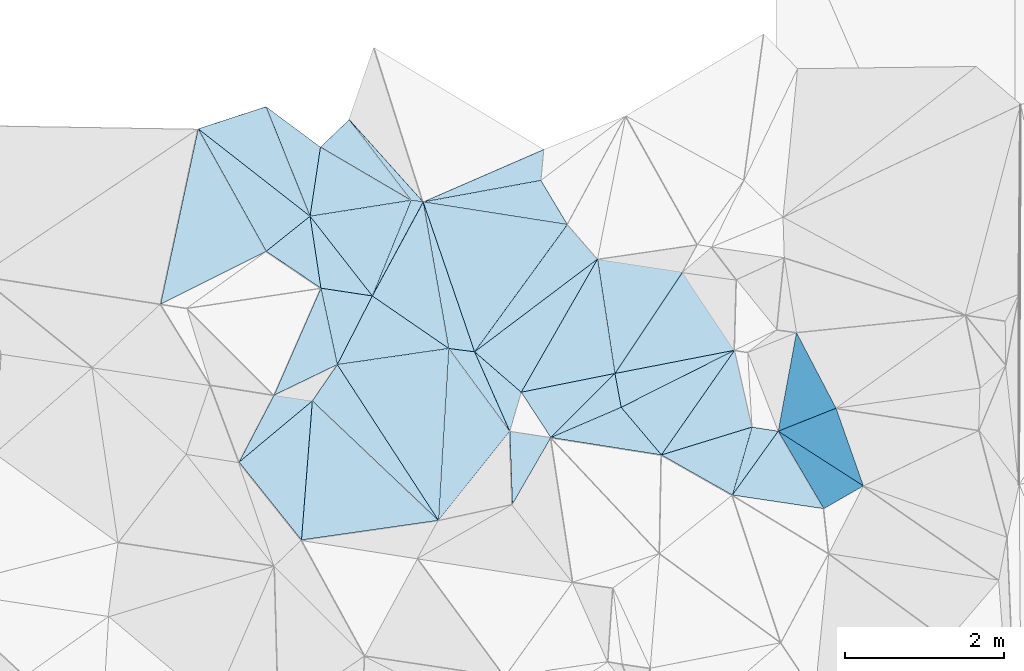
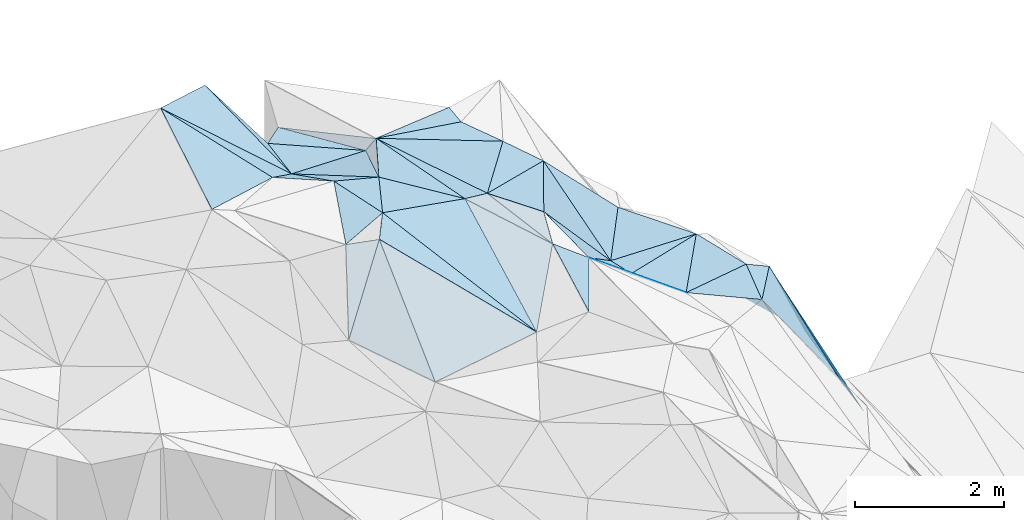
# One storey, part 142 of 275: 45 plates.
"""IFC2X3 building model written with IfcOpenShell, lengths in millimetres."""

from ifc_helpers import new_model, si_unit, frame, origin_with_axes, place, context, subcontext, project, spatial, polyline, outline, extrude, material, type_object, element, save


model = new_model("IFC2X3")

# Units and contexts
model_context = context("Model", 3, precision=1e-05, world=origin_with_axes())
body_context = subcontext(model_context, "Body", "Model", "MODEL_VIEW")
ifc_project = project(units=[si_unit("LENGTHUNIT", "METRE", prefix="MILLI"), si_unit("AREAUNIT", "SQUARE_METRE"), si_unit("VOLUMEUNIT", "CUBIC_METRE"), si_unit("MASSUNIT", "GRAM", prefix="KILO"), si_unit("TIMEUNIT", "SECOND"), si_unit("PLANEANGLEUNIT", "RADIAN"), si_unit("SOLIDANGLEUNIT", "STERADIAN"), si_unit("THERMODYNAMICTEMPERATUREUNIT", "DEGREE_CELSIUS"), si_unit("LUMINOUSINTENSITYUNIT", "LUMEN")], contexts=[model_context])

# Site, building, storey
site_placement = place(None, origin_with_axes())
site = spatial("IfcSite", under=ifc_project, at=site_placement, CompositionType="ELEMENT")
building_placement = place(site_placement, origin_with_axes())
building = spatial("IfcBuilding", under=site, at=building_placement, Name="Undefined", CompositionType="ELEMENT")
storey_placement = place(building_placement, origin_with_axes())
storey = spatial("IfcBuildingStorey", under=building, at=storey_placement, Name="Undefined", CompositionType="ELEMENT", Elevation=0.0)

# Plates
ifc_material = material()
plate_type_1 = type_object("IfcPlateType", PredefinedType="NOTDEFINED")
plate_1_placement = place(storey_placement, frame((-104767.523451907, 132983.960648747, 53559.5339782544), z_axis=(0.027937573258607, 0.361384984998901, -0.931998060415237), x_axis=(0.568975581629872, -0.772337626028646, -0.282420571009594)))
element("IfcPlate", 1, at=plate_1_placement, inside=storey, type_object=plate_type_1, material=ifc_material, Name="00", context=body_context, shape_type="SweptSolid", body=[
    extrude(outline(polyline([(0.0, 0.0), (1345.51110839844, -8.24911694508046e-09), (1829.19348144531, 1423.42944335938), (0.0, 0.0)])), frame((-8.85201319254618e-08, 2.18876761149539e-07, -0.5000001331573), z_axis=(0.0, 0.0, 1.0), x_axis=(1.0, 0.0, 0.0)), (0.0, 0.0, 1.0), 1.0),
])
plate_type_2 = type_object("IfcPlateType", PredefinedType="NOTDEFINED")
plate_2_placement = place(storey_placement, frame((-107909.863695249, 135738.566040007, 54479.5298846672), z_axis=(-0.310856798938635, 0.139361866753674, -0.94018419506422), x_axis=(0.466681802813853, -0.839359615220943, -0.278717655089451)))
element("IfcPlate", 2, at=plate_2_placement, inside=storey, type_object=plate_type_2, material=ifc_material, Name="00", context=body_context, shape_type="SweptSolid", body=[
    extrude(outline(polyline([(0.0, 0.0), (1829.80871582031, 2.2373569663614e-08), (1672.57922363281, 1512.01147460938), (0.0, 0.0)])), frame((-8.85201319254618e-08, 2.18876761149539e-07, -0.5000001331573), z_axis=(0.0, 0.0, 1.0), x_axis=(1.0, 0.0, 0.0)), (0.0, 0.0, 1.0), 1.0),
])
plate_type_3 = type_object("IfcPlateType", PredefinedType="NOTDEFINED")
plate_3_placement = place(storey_placement, frame((-105087.96091564, 134821.179670873, 53549.5185264077), z_axis=(-0.269571440745411, 0.0123080140453216, -0.962901734926625), x_axis=(0.948921792176216, 0.173630967684397, -0.263438264863057)))
element("IfcPlate", 3, at=plate_3_placement, inside=storey, type_object=plate_type_3, material=ifc_material, Name="00", context=body_context, shape_type="SweptSolid", body=[
    extrude(outline(polyline([(0.0, 0.0), (1556.34191894531, -8.44011083245277e-10), (1801.66076660156, 604.829467773438), (0.0, 0.0)])), frame((-8.85201319254618e-08, 2.18876761149539e-07, -0.5000001331573), z_axis=(0.0, 0.0, 1.0), x_axis=(1.0, 0.0, 0.0)), (0.0, 0.0, 1.0), 1.0),
])
plate_type_4 = type_object("IfcPlateType", PredefinedType="NOTDEFINED")
plate_4_placement = place(storey_placement, frame((-100406.635378248, 133184.214775604, 50339.7691681341), z_axis=(-0.823962599843312, -0.328621352157269, -0.461620667827794), x_axis=(0.454552533172392, -0.869738022329497, -0.192192005819538)))
element("IfcPlate", 4, at=plate_4_placement, inside=storey, type_object=plate_type_4, material=ifc_material, Name="00", context=body_context, shape_type="SweptSolid", body=[
    extrude(outline(polyline([(0.0, 0.0), (1092.65734863281, 1.22454366646707e-08), (725.021484375, 1650.498046875), (0.0, 0.0)])), frame((-8.85201319254618e-08, 2.18876761149539e-07, -0.5000001331573), z_axis=(0.0, 0.0, 1.0), x_axis=(1.0, 0.0, 0.0)), (0.0, 0.0, 1.0), 1.0),
])
plate_type_5 = type_object("IfcPlateType", PredefinedType="NOTDEFINED")
plate_5_placement = place(storey_placement, frame((-107909.991424858, 135738.475589161, 54479.5884071762), z_axis=(-0.566319204344886, -0.0415407712196179, -0.823138459262265), x_axis=(0.70166753260825, -0.548238259765341, -0.455079646010367)))
element("IfcPlate", 5, at=plate_5_placement, inside=storey, type_object=plate_type_5, material=ifc_material, Name="00", context=body_context, shape_type="SweptSolid", body=[
    extrude(outline(polyline([(0.0, 0.0), (1999.65002441406, -6.46105036139488e-09), (1673.29284667969, 740.466735839844), (0.0, 0.0)])), frame((-8.85201319254618e-08, 2.18876761149539e-07, -0.5000001331573), z_axis=(0.0, 0.0, 1.0), x_axis=(1.0, 0.0, 0.0)), (0.0, 0.0, 1.0), 1.0),
])
plate_type_6 = type_object("IfcPlateType", PredefinedType="NOTDEFINED")
plate_6_placement = place(storey_placement, frame((-106370.298706913, 133740.320928049, 53949.50002438), z_axis=(0.00686190620251637, 0.0118964988761365, -0.999905689331628), x_axis=(0.209295559354829, -0.977799256644199, -0.0101971829639996)))
element("IfcPlate", 6, at=plate_6_placement, inside=storey, type_object=plate_type_6, material=ifc_material, Name="00", context=body_context, shape_type="SweptSolid", body=[
    extrude(outline(polyline([(0.0, 0.0), (980.663024902344, 1.18889147415757e-08), (1189.60327148438, 855.420349121094), (0.0, 0.0)])), frame((-8.85201319254618e-08, 2.18876761149539e-07, -0.5000001331573), z_axis=(0.0, 0.0, 1.0), x_axis=(1.0, 0.0, 0.0)), (0.0, 0.0, 1.0), 1.0),
])
plate_type_7 = type_object("IfcPlateType", PredefinedType="NOTDEFINED")
plate_7_placement = place(storey_placement, frame((-107059.703510262, 136016.080289449, 54389.6845159088), z_axis=(-0.773071236838612, 0.0655685188885672, -0.630921256658529), x_axis=(0.554981887379957, -0.411747694578096, -0.722813212863326)))
element("IfcPlate", 7, at=plate_7_placement, inside=storey, type_object=plate_type_7, material=ifc_material, Name="00", context=body_context, shape_type="SweptSolid", body=[
    extrude(outline(polyline([(0.0, 0.0), (1231.30017089844, -9.42964106798172e-09), (1465.11804199219, 847.778991699219), (0.0, 0.0)])), frame((-8.85201319254618e-08, 2.18876761149539e-07, -0.5000001331573), z_axis=(0.0, 0.0, 1.0), x_axis=(1.0, 0.0, 0.0)), (0.0, 0.0, 1.0), 1.0),
])
plate_type_8 = type_object("IfcPlateType", PredefinedType="NOTDEFINED")
plate_8_placement = place(storey_placement, frame((-102682.942132012, 132669.929577639, 51999.6181160321), z_axis=(-0.627445474105502, -0.151785210025526, -0.763723396945536), x_axis=(0.181311734376374, -0.982336361632116, 0.0462744810106784)))
element("IfcPlate", 8, at=plate_8_placement, inside=storey, type_object=plate_type_8, material=ifc_material, Name="00", context=body_context, shape_type="SweptSolid", body=[
    extrude(outline(polyline([(0.0, 0.0), (432.203643798828, 1.20780896395445e-09), (681.623107910156, 1224.53662109375), (0.0, 0.0)])), frame((-8.85201319254618e-08, 2.18876761149539e-07, -0.5000001331573), z_axis=(0.0, 0.0, 1.0), x_axis=(1.0, 0.0, 0.0)), (0.0, 0.0, 1.0), 1.0),
])
plate_type_9 = type_object("IfcPlateType", PredefinedType="NOTDEFINED")
plate_9_placement = place(storey_placement, frame((-103969.479592745, 131029.926808789, 52609.6198368029), z_axis=(-0.461484012142877, 0.457167268220081, -0.760283233673281), x_axis=(-0.0303457624267116, 0.848360430696387, 0.528548686812655)))
element("IfcPlate", 9, at=plate_9_placement, inside=storey, type_object=plate_type_9, material=ifc_material, Name="00", context=body_context, shape_type="SweptSolid", body=[
    extrude(outline(polyline([(0.0, 0.0), (1078.4248046875, -5.28234522789717e-09), (806.175842285156, 572.259155273438), (0.0, 0.0)])), frame((-8.85201319254618e-08, 2.18876761149539e-07, -0.5000001331573), z_axis=(0.0, 0.0, 1.0), x_axis=(1.0, 0.0, 0.0)), (0.0, 0.0, 1.0), 1.0),
])
plate_type_10 = type_object("IfcPlateType", PredefinedType="NOTDEFINED")
plate_10_placement = place(storey_placement, frame((-106165.132080624, 132781.41177076, 53939.506291353), z_axis=(-0.156711149483167, -0.0232466390697115, -0.987370857074295), x_axis=(-0.209295559392846, 0.97779925663596, 0.010197182973742)))
element("IfcPlate", 10, at=plate_10_placement, inside=storey, type_object=plate_type_10, material=ifc_material, Name="00", context=body_context, shape_type="SweptSolid", body=[
    extrude(outline(polyline([(0.0, 0.0), (980.663024902344, 1.18889147415757e-08), (749.18701171875, 617.591186523438), (0.0, 0.0)])), frame((-8.85201319254618e-08, 2.18876761149539e-07, -0.5000001331573), z_axis=(0.0, 0.0, 1.0), x_axis=(1.0, 0.0, 0.0)), (0.0, 0.0, 1.0), 1.0),
])
plate_type_11 = type_object("IfcPlateType", PredefinedType="NOTDEFINED")
plate_11_placement = place(storey_placement, frame((-102099.898604639, 131648.453920345, 51889.5114577893), z_axis=(-0.210126802402221, 0.0351965216204945, -0.977040394138357), x_axis=(-0.636686709410715, 0.75346574778832, 0.164071328907716)))
element("IfcPlate", 11, at=plate_11_placement, inside=storey, type_object=plate_type_11, material=ifc_material, Name="00", context=body_context, shape_type="SweptSolid", body=[
    extrude(outline(polyline([(0.0, 0.0), (792.338317871094, 1.54614099301398e-10), (380.645477294922, 1563.14074707031), (0.0, 0.0)])), frame((-8.85201319254618e-08, 2.18876761149539e-07, -0.5000001331573), z_axis=(0.0, 0.0, 1.0), x_axis=(1.0, 0.0, 0.0)), (0.0, 0.0, 1.0), 1.0),
])
plate_type_12 = type_object("IfcPlateType", PredefinedType="NOTDEFINED")
plate_12_placement = place(storey_placement, frame((-102604.342852343, 132245.398501613, 52019.5075385165), z_axis=(-0.156072862233273, -0.0752009145151501, -0.984878715441855), x_axis=(-0.181311734386295, 0.982336361630361, -0.0462744810090589)))
element("IfcPlate", 12, at=plate_12_placement, inside=storey, type_object=plate_type_12, material=ifc_material, Name="00", context=body_context, shape_type="SweptSolid", body=[
    extrude(outline(polyline([(0.0, 0.0), (432.203643798828, 1.20780896395445e-09), (458.580108642578, 1550.03369140625), (0.0, 0.0)])), frame((-8.85201319254618e-08, 2.18876761149539e-07, -0.5000001331573), z_axis=(0.0, 0.0, 1.0), x_axis=(1.0, 0.0, 0.0)), (0.0, 0.0, 1.0), 1.0),
])
plate_type_13 = type_object("IfcPlateType", PredefinedType="NOTDEFINED")
plate_13_placement = place(storey_placement, frame((-103574.814646294, 135479.194483607, 53129.5182037541), z_axis=(-0.267534526374964, 0.000195026263652209, -0.963548254713836), x_axis=(-0.0931650974078648, -0.995319799413613, 0.0256663499592105)))
element("IfcPlate", 13, at=plate_13_placement, inside=storey, type_object=plate_type_13, material=ifc_material, Name="00", context=body_context, shape_type="SweptSolid", body=[
    extrude(outline(polyline([(0.0, 0.0), (389.615203857422, -5.29689714312553e-09), (806.693359375, 1499.41516113281), (0.0, 0.0)])), frame((-8.85201319254618e-08, 2.18876761149539e-07, -0.5000001331573), z_axis=(0.0, 0.0, 1.0), x_axis=(1.0, 0.0, 0.0)), (0.0, 0.0, 1.0), 1.0),
])
plate_type_14 = type_object("IfcPlateType", PredefinedType="NOTDEFINED")
plate_14_placement = place(storey_placement, frame((-106506.718752455, 134642.00877305, 53569.5540932732), z_axis=(-0.199901119655216, -0.405945734111663, -0.891766563242385), x_axis=(0.601132466315205, -0.769530860631351, 0.215550487073842)))
element("IfcPlate", 14, at=plate_14_placement, inside=storey, type_object=plate_type_14, material=ifc_material, Name="00", context=body_context, shape_type="SweptSolid", body=[
    extrude(outline(polyline([(0.0, 0.0), (1298.99963378906, 1.61526259034872e-09), (857.890930175781, 490.329620361328), (0.0, 0.0)])), frame((-8.85201319254618e-08, 2.18876761149539e-07, -0.5000001331573), z_axis=(0.0, 0.0, 1.0), x_axis=(1.0, 0.0, 0.0)), (0.0, 0.0, 1.0), 1.0),
])
plate_type_15 = type_object("IfcPlateType", PredefinedType="NOTDEFINED")
plate_15_placement = place(storey_placement, frame((-106477.684411031, 132326.436471956, 53889.5939063843), z_axis=(-0.0499571551713603, 0.58131586940463, -0.812142932386611), x_axis=(0.639363766046095, -0.606085776496801, -0.473153258675902)))
element("IfcPlate", 15, at=plate_15_placement, inside=storey, type_object=plate_type_15, material=ifc_material, Name="00", context=body_context, shape_type="SweptSolid", body=[
    extrude(outline(polyline([(0.0, 0.0), (2472.77172851563, 7.38509697839618e-09), (1556.55285644531, 1474.87048339844), (0.0, 0.0)])), frame((-8.85201319254618e-08, 2.18876761149539e-07, -0.5000001331573), z_axis=(0.0, 0.0, 1.0), x_axis=(1.0, 0.0, 0.0)), (0.0, 0.0, 1.0), 1.0),
])
plate_type_16 = type_object("IfcPlateType", PredefinedType="NOTDEFINED")
plate_16_placement = place(storey_placement, frame((-104767.70148436, 132983.748800406, 53559.5286885965), z_axis=(-0.328121166845407, -0.0623270220135051, -0.942577234074183), x_axis=(-0.799536616078512, 0.549716265458906, 0.241977740793727)))
element("IfcPlate", 16, at=plate_16_placement, inside=storey, type_object=plate_type_16, material=ifc_material, Name="00", context=body_context, shape_type="SweptSolid", body=[
    extrude(outline(polyline([(0.0, 0.0), (1198.45739746094, -5.68252289667726e-09), (1263.70788574219, 1371.76611328125), (0.0, 0.0)])), frame((-8.85201319254618e-08, 2.18876761149539e-07, -0.5000001331573), z_axis=(0.0, 0.0, 1.0), x_axis=(1.0, 0.0, 0.0)), (0.0, 0.0, 1.0), 1.0),
])
plate_type_17 = type_object("IfcPlateType", PredefinedType="NOTDEFINED")
plate_17_placement = place(storey_placement, frame((-106613.9450078, 130582.31431037, 52649.6056106906), z_axis=(0.298464084649345, 0.537417319037725, -0.788734312283124), x_axis=(-0.599114151318179, 0.748794737710297, 0.283493693876363)))
element("IfcPlate", 17, at=plate_17_placement, inside=storey, type_object=plate_type_17, material=ifc_material, Name="00", context=body_context, shape_type="SweptSolid", body=[
    extrude(outline(polyline([(0.0, 0.0), (1305.14367675781, -6.87577994540334e-09), (1575.76525878906, 1454.32592773438), (0.0, 0.0)])), frame((-8.85201319254618e-08, 2.18876761149539e-07, -0.5000001331573), z_axis=(0.0, 0.0, 1.0), x_axis=(1.0, 0.0, 0.0)), (0.0, 0.0, 1.0), 1.0),
])
plate_type_18 = type_object("IfcPlateType", PredefinedType="NOTDEFINED")
plate_18_placement = place(storey_placement, frame((-105238.771293662, 134841.533894923, 53389.6838441518), z_axis=(0.602509255979586, -0.487054469395573, -0.632266194178309), x_axis=(0.683959945897054, -0.0931740805745993, 0.723545011120647)))
element("IfcPlate", 18, at=plate_18_placement, inside=storey, type_object=plate_type_18, material=ifc_material, Name="00", context=body_context, shape_type="SweptSolid", body=[
    extrude(outline(polyline([(0.0, 0.0), (221.133438110352, 2.03726813197136e-10), (111.697257995605, 1368.94982910156), (0.0, 0.0)])), frame((-8.85201319254618e-08, 2.18876761149539e-07, -0.5000001331573), z_axis=(0.0, 0.0, 1.0), x_axis=(1.0, 0.0, 0.0)), (0.0, 0.0, 1.0), 1.0),
])
plate_type_19 = type_object("IfcPlateType", PredefinedType="NOTDEFINED")
plate_19_placement = place(storey_placement, frame((-100635.508167043, 131946.211296459, 51629.7705520988), z_axis=(-0.86205191849835, 0.21522386317704, -0.458852022478342), x_axis=(0.402758664213005, -0.258667042773612, -0.877995910801475)))
element("IfcPlate", 19, at=plate_19_placement, inside=storey, type_object=plate_type_19, material=ifc_material, Name="00", context=body_context, shape_type="SweptSolid", body=[
    extrude(outline(polyline([(0.0, 0.0), (2653.77099609375, -6.49015419185162e-09), (1824.98803710938, 530.677734375), (0.0, 0.0)])), frame((-8.85201319254618e-08, 2.18876761149539e-07, -0.5000001331573), z_axis=(0.0, 0.0, 1.0), x_axis=(1.0, 0.0, 0.0)), (0.0, 0.0, 1.0), 1.0),
])
plate_type_20 = type_object("IfcPlateType", PredefinedType="NOTDEFINED")
plate_20_placement = place(storey_placement, frame((-104442.709369791, 132941.510169452, 53559.4999851938), z_axis=(-0.000724607123410033, -0.00556871754484436, -0.999984232040397), x_axis=(-0.991640266387544, 0.129033259583881, -1.75631349472209e-10)))
element("IfcPlate", 20, at=plate_20_placement, inside=storey, type_object=plate_type_20, material=ifc_material, Name="00", context=body_context, shape_type="SweptSolid", body=[
    extrude(outline(polyline([(0.0, 0.0), (327.566772460938, 6.83940015733242e-10), (882.262817382813, 1780.73364257813), (0.0, 0.0)])), frame((-8.85201319254618e-08, 2.18876761149539e-07, -0.5000001331573), z_axis=(0.0, 0.0, 1.0), x_axis=(1.0, 0.0, 0.0)), (0.0, 0.0, 1.0), 1.0),
])
plate_type_21 = type_object("IfcPlateType", PredefinedType="NOTDEFINED")
plate_21_placement = place(storey_placement, frame((-100635.439578499, 131946.316657291, 51629.7292658031), z_axis=(-0.724867893358192, 0.42594065589623, -0.541425059295509), x_axis=(0.300836640339334, -0.511315458779204, -0.80501789883378)))
element("IfcPlate", 21, at=plate_21_placement, inside=storey, type_object=plate_type_21, material=ifc_material, Name="00", context=body_context, shape_type="SweptSolid", body=[
    extrude(outline(polyline([(0.0, 0.0), (1900.57885742188, 3.5543052945286e-09), (123.804389953613, 988.317993164063), (0.0, 0.0)])), frame((-8.85201319254618e-08, 2.18876761149539e-07, -0.5000001331573), z_axis=(0.0, 0.0, 1.0), x_axis=(1.0, 0.0, 0.0)), (0.0, 0.0, 1.0), 1.0),
])
plate_type_22 = type_object("IfcPlateType", PredefinedType="NOTDEFINED")
plate_22_placement = place(storey_placement, frame((-101210.384584347, 131145.114655179, 51769.5040283182), z_axis=(-0.12632687213663, 0.0132394858402389, -0.991900316257063), x_axis=(-0.864380306883383, 0.489129499459649, 0.116614826804068)))
element("IfcPlate", 22, at=plate_22_placement, inside=storey, type_object=plate_type_22, material=ifc_material, Name="00", context=body_context, shape_type="SweptSolid", body=[
    extrude(outline(polyline([(0.0, 0.0), (1029.02868652344, -1.05137587524951e-08), (201.646469116211, 864.314025878906), (0.0, 0.0)])), frame((-8.85201319254618e-08, 2.18876761149539e-07, -0.5000001331573), z_axis=(0.0, 0.0, 1.0), x_axis=(1.0, 0.0, 0.0)), (0.0, 0.0, 1.0), 1.0),
])
plate_type_23 = type_object("IfcPlateType", PredefinedType="NOTDEFINED")
plate_23_placement = place(storey_placement, frame((-101182.442662887, 132961.493213589, 51739.5034129469), z_axis=(-0.111479866505004, -0.0355632137240844, -0.993130151185453), x_axis=(0.220982835409055, -0.975225226694047, 0.0101165050348614)))
element("IfcPlate", 23, at=plate_23_placement, inside=storey, type_object=plate_type_23, material=ifc_material, Name="00", context=body_context, shape_type="SweptSolid", body=[
    extrude(outline(polyline([(0.0, 0.0), (988.483703613281, -5.4424162954092e-09), (1079.32995605469, 1193.041015625), (0.0, 0.0)])), frame((-8.85201319254618e-08, 2.18876761149539e-07, -0.5000001331573), z_axis=(0.0, 0.0, 1.0), x_axis=(1.0, 0.0, 0.0)), (0.0, 0.0, 1.0), 1.0),
])
plate_type_24 = type_object("IfcPlateType", PredefinedType="NOTDEFINED")
plate_24_placement = place(storey_placement, frame((-103279.246274558, 134538.411590522, 53039.5488337942), z_axis=(-0.430671414689016, 0.0200225732834566, -0.90228666682428), x_axis=(0.623327467411278, -0.716401825560448, -0.313418717858874)))
element("IfcPlate", 24, at=plate_24_placement, inside=storey, type_object=plate_type_24, material=ifc_material, Name="00", context=body_context, shape_type="SweptSolid", body=[
    extrude(outline(polyline([(0.0, 0.0), (606.2177734375, -8.06358002591878e-09), (255.683685302734, 2027.12255859375), (0.0, 0.0)])), frame((-8.85201319254618e-08, 2.18876761149539e-07, -0.5000001331573), z_axis=(0.0, 0.0, 1.0), x_axis=(1.0, 0.0, 0.0)), (0.0, 0.0, 1.0), 1.0),
])
plate_type_25 = type_object("IfcPlateType", PredefinedType="NOTDEFINED")
plate_25_placement = place(storey_placement, frame((-105087.499847523, 134821.434291555, 53549.7251299879), z_axis=(0.65255739452273, 0.52154025346078, -0.54969501623516), x_axis=(-0.683959945895793, 0.0931740806130376, -0.723545011116889)))
element("IfcPlate", 25, at=plate_25_placement, inside=storey, type_object=plate_type_25, material=ifc_material, Name="00", context=body_context, shape_type="SweptSolid", body=[
    extrude(outline(polyline([(0.0, 0.0), (221.133438110352, 2.03726813197136e-10), (817.153625488281, 1128.69836425781), (0.0, 0.0)])), frame((-8.85201319254618e-08, 2.18876761149539e-07, -0.5000001331573), z_axis=(0.0, 0.0, 1.0), x_axis=(1.0, 0.0, 0.0)), (0.0, 0.0, 1.0), 1.0),
])
plate_type_26 = type_object("IfcPlateType", PredefinedType="NOTDEFINED")
plate_26_placement = place(storey_placement, frame((-106506.734868149, 134642.425717093, 53569.5632385556), z_axis=(-0.232123529757676, 0.427967513749586, -0.873477231590976), x_axis=(-0.701667532627674, 0.548238259738527, 0.45507964601272)))
element("IfcPlate", 26, at=plate_26_placement, inside=storey, type_object=plate_type_26, material=ifc_material, Name="00", context=body_context, shape_type="SweptSolid", body=[
    extrude(outline(polyline([(0.0, 0.0), (1999.65002441406, -6.46105036139488e-09), (1514.1650390625, 756.706237792969), (0.0, 0.0)])), frame((-8.85201319254618e-08, 2.18876761149539e-07, -0.5000001331573), z_axis=(0.0, 0.0, 1.0), x_axis=(1.0, 0.0, 0.0)), (0.0, 0.0, 1.0), 1.0),
])
plate_type_27 = type_object("IfcPlateType", PredefinedType="NOTDEFINED")
plate_27_placement = place(storey_placement, frame((-106957.752298053, 132398.523804418, 53929.654970516), z_axis=(0.050813186163484, 0.722009309961996, -0.690014910302754), x_axis=(0.985596979308793, -0.147838000634197, -0.0821128488475886)))
element("IfcPlate", 27, at=plate_27_placement, inside=storey, type_object=plate_type_27, material=ifc_material, Name="00", context=body_context, shape_type="SweptSolid", body=[
    extrude(outline(polyline([(0.0, 0.0), (487.134490966797, -2.43016984313726e-09), (-233.200485229492, 1292.05944824219), (0.0, 0.0)])), frame((-8.85201319254618e-08, 2.18876761149539e-07, -0.5000001331573), z_axis=(0.0, 0.0, 1.0), x_axis=(1.0, 0.0, 0.0)), (0.0, 0.0, 1.0), 1.0),
])
plate_type_28 = type_object("IfcPlateType", PredefinedType="NOTDEFINED")
plate_28_placement = place(storey_placement, frame((-105239.138659933, 134841.746322666, 53389.5053451074), z_axis=(-0.132231293058365, -0.0622133105755877, -0.989264569831215), x_axis=(-0.859436516344823, 0.504434528507614, 0.0831545598411492)))
element("IfcPlate", 28, at=plate_28_placement, inside=storey, type_object=plate_type_28, material=ifc_material, Name="00", context=body_context, shape_type="SweptSolid", body=[
    extrude(outline(polyline([(0.0, 0.0), (1322.837890625, 7.8580342233181e-09), (1180.94592285156, 484.320861816406), (0.0, 0.0)])), frame((-8.85201319254618e-08, 2.18876761149539e-07, -0.5000001331573), z_axis=(0.0, 0.0, 1.0), x_axis=(1.0, 0.0, 0.0)), (0.0, 0.0, 1.0), 1.0),
])
plate_type_29 = type_object("IfcPlateType", PredefinedType="NOTDEFINED")
plate_29_placement = place(storey_placement, frame((-101210.487243979, 131145.144931426, 51769.5297211063), z_axis=(-0.331643205582508, 0.0737878990902126, -0.940514821860246), x_axis=(0.277595035684523, 0.96043385438251, -0.0225345849587841)))
element("IfcPlate", 29, at=plate_29_placement, inside=storey, type_object=plate_type_29, material=ifc_material, Name="00", context=body_context, shape_type="SweptSolid", body=[
    extrude(outline(polyline([(0.0, 0.0), (887.524658203125, 8.46921466290951e-09), (932.143127441406, 351.011657714844), (0.0, 0.0)])), frame((-8.85201319254618e-08, 2.18876761149539e-07, -0.5000001331573), z_axis=(0.0, 0.0, 1.0), x_axis=(1.0, 0.0, 0.0)), (0.0, 0.0, 1.0), 1.0),
])
plate_type_30 = type_object("IfcPlateType", PredefinedType="NOTDEFINED")
plate_30_placement = place(storey_placement, frame((-103486.711818219, 131866.467037978, 52819.6804772273), z_axis=(-0.761381159512719, 0.109437701378822, -0.639000875943052), x_axis=(-0.428249220407521, 0.655092198811147, 0.622460292932109)))
element("IfcPlate", 30, at=plate_30_placement, inside=storey, type_object=plate_type_30, material=ifc_material, Name="00", context=body_context, shape_type="SweptSolid", body=[
    extrude(outline(polyline([(0.0, 0.0), (867.525207519531, -7.34144123271108e-09), (-328.174896240234, 1362.49816894531), (0.0, 0.0)])), frame((-8.85201319254618e-08, 2.18876761149539e-07, -0.5000001331573), z_axis=(0.0, 0.0, 1.0), x_axis=(1.0, 0.0, 0.0)), (0.0, 0.0, 1.0), 1.0),
])
plate_31_placement = place(storey_placement, frame((-106370.452498573, 133740.110711257, 53949.5690837898), z_axis=(-0.300689372410471, -0.408547425571801, -0.86178587965808), x_axis=(-0.828817521340246, 0.558996172606265, 0.0241825418630555)))
element("IfcPlate", 31, at=plate_31_placement, inside=storey, type_object=plate_type_30, material=ifc_material, Name="00", context=body_context, shape_type="SweptSolid", body=[
    extrude(outline(polyline([(0.0, 0.0), (827.042907714844, 2.47018761001527e-09), (607.949096679688, 778.972351074219), (0.0, 0.0)])), frame((-8.85201319254618e-08, 2.18876761149539e-07, -0.5000001331573), z_axis=(0.0, 0.0, 1.0), x_axis=(1.0, 0.0, 0.0)), (0.0, 0.0, 1.0), 1.0),
])
plate_type_31 = type_object("IfcPlateType", PredefinedType="NOTDEFINED")
plate_32_placement = place(storey_placement, frame((-106506.659833038, 134642.047869244, 53569.5293770261), z_axis=(-0.0820569356081556, -0.327736059212904, -0.941199094140127), x_axis=(0.97825348823684, 0.154018708598084, -0.138918501842751)))
element("IfcPlate", 32, at=plate_32_placement, inside=storey, type_object=plate_type_31, material=ifc_material, Name="00", context=body_context, shape_type="SweptSolid", body=[
    extrude(outline(polyline([(0.0, 0.0), (1295.72375488281, -3.73984221369028e-09), (571.0322265625, 1166.75708007813), (0.0, 0.0)])), frame((-8.85201319254618e-08, 2.18876761149539e-07, -0.5000001331573), z_axis=(0.0, 0.0, 1.0), x_axis=(1.0, 0.0, 0.0)), (0.0, 0.0, 1.0), 1.0),
])
plate_type_32 = type_object("IfcPlateType", PredefinedType="NOTDEFINED")
plate_33_placement = place(storey_placement, frame((-104442.717860783, 132941.687581595, 53559.5315502099), z_axis=(-0.0177201289588489, 0.349269983379335, -0.936854564881808), x_axis=(0.731705179152575, -0.634034639522538, -0.250215120819712)))
element("IfcPlate", 33, at=plate_33_placement, inside=storey, type_object=plate_type_32, material=ifc_material, Name="00", context=body_context, shape_type="SweptSolid", body=[
    extrude(outline(polyline([(0.0, 0.0), (799.312194824219, 6.40284270048141e-10), (1049.65246582031, 480.343383789063), (0.0, 0.0)])), frame((-8.85201319254618e-08, 2.18876761149539e-07, -0.5000001331573), z_axis=(0.0, 0.0, 1.0), x_axis=(1.0, 0.0, 0.0)), (0.0, 0.0, 1.0), 1.0),
])
plate_type_33 = type_object("IfcPlateType", PredefinedType="NOTDEFINED")
plate_34_placement = place(storey_placement, frame((-106165.200244479, 132781.604502827, 53939.5575646231), z_axis=(-0.293043457982504, 0.36222913885631, -0.884825170695925), x_axis=(0.955679808316581, 0.138379843490056, -0.259859813922144)))
element("IfcPlate", 34, at=plate_34_placement, inside=storey, type_object=plate_type_33, material=ifc_material, Name="00", context=body_context, shape_type="SweptSolid", body=[
    extrude(outline(polyline([(0.0, 0.0), (1462.32690429688, -1.92085281014442e-09), (1258.81567382813, 2308.8271484375), (0.0, 0.0)])), frame((-8.85201319254618e-08, 2.18876761149539e-07, -0.5000001331573), z_axis=(0.0, 0.0, 1.0), x_axis=(1.0, 0.0, 0.0)), (0.0, 0.0, 1.0), 1.0),
])
plate_type_34 = type_object("IfcPlateType", PredefinedType="NOTDEFINED")
plate_35_placement = place(storey_placement, frame((-105725.881455694, 133642.609240153, 53849.518458065), z_axis=(-0.267009828867948, 0.0355628542576127, -0.963037400460107), x_axis=(0.799536616074366, -0.549716265464827, -0.241977740793975)))
element("IfcPlate", 35, at=plate_35_placement, inside=storey, type_object=plate_type_34, material=ifc_material, Name="00", context=body_context, shape_type="SweptSolid", body=[
    extrude(outline(polyline([(0.0, 0.0), (1198.45739746094, -5.68252289667726e-09), (100.379043579102, 965.724609375), (0.0, 0.0)])), frame((-8.85201319254618e-08, 2.18876761149539e-07, -0.5000001331573), z_axis=(0.0, 0.0, 1.0), x_axis=(1.0, 0.0, 0.0)), (0.0, 0.0, 1.0), 1.0),
])
plate_type_35 = type_object("IfcPlateType", PredefinedType="NOTDEFINED")
plate_36_placement = place(storey_placement, frame((-104896.828479458, 130827.598927565, 52719.5594949503), z_axis=(-0.339352179258407, 0.329758580727491, -0.880965025905774), x_axis=(-0.639363766083002, 0.606085776446773, 0.473153258690112)))
element("IfcPlate", 36, at=plate_36_placement, inside=storey, type_object=plate_type_35, material=ifc_material, Name="00", context=body_context, shape_type="SweptSolid", body=[
    extrude(outline(polyline([(0.0, 0.0), (2472.77172851563, 7.38509697839618e-09), (2572.49780273438, 545.485717773438), (0.0, 0.0)])), frame((-8.85201319254618e-08, 2.18876761149539e-07, -0.5000001331573), z_axis=(0.0, 0.0, 1.0), x_axis=(1.0, 0.0, 0.0)), (0.0, 0.0, 1.0), 1.0),
])
plate_type_36 = type_object("IfcPlateType", PredefinedType="NOTDEFINED")
plate_37_placement = place(storey_placement, frame((-101834.428645668, 133941.567426883, 51809.5070698236), z_axis=(-0.163407055483903, -0.0382907085425995, -0.985815376151836), x_axis=(0.552885826672385, -0.831139789956941, -0.059362548927119)))
element("IfcPlate", 37, at=plate_37_placement, inside=storey, type_object=plate_type_36, material=ifc_material, Name="00", context=body_context, shape_type="SweptSolid", body=[
    extrude(outline(polyline([(0.0, 0.0), (1179.19458007813, 2.48837750405073e-09), (576.579956054688, 1428.34008789063), (0.0, 0.0)])), frame((-8.85201319254618e-08, 2.18876761149539e-07, -0.5000001331573), z_axis=(0.0, 0.0, 1.0), x_axis=(1.0, 0.0, 0.0)), (0.0, 0.0, 1.0), 1.0),
])
plate_type_37 = type_object("IfcPlateType", PredefinedType="NOTDEFINED")
plate_38_placement = place(storey_placement, frame((-99566.6992713835, 131259.683755675, 49299.7861088844), z_axis=(-0.902715465658368, 0.0463022373918267, -0.427739279086813), x_axis=(-0.402758664204674, 0.258667042794605, 0.877995910799111)))
element("IfcPlate", 38, at=plate_38_placement, inside=storey, type_object=plate_type_37, material=ifc_material, Name="00", context=body_context, shape_type="SweptSolid", body=[
    extrude(outline(polyline([(0.0, 0.0), (2653.77099609375, -6.49015419185162e-09), (1119.04907226563, 709.879638671875), (0.0, 0.0)])), frame((-8.85201319254618e-08, 2.18876761149539e-07, -0.5000001331573), z_axis=(0.0, 0.0, 1.0), x_axis=(1.0, 0.0, 0.0)), (0.0, 0.0, 1.0), 1.0),
])
plate_type_38 = type_object("IfcPlateType", PredefinedType="NOTDEFINED")
plate_39_placement = place(storey_placement, frame((-102100.07495779, 131648.282004568, 51889.6165824781), z_axis=(-0.562832898026171, -0.308626892673308, -0.766791086292923), x_axis=(-0.823498425981813, 0.129461251620406, 0.552349641743664)))
element("IfcPlate", 39, at=plate_39_placement, inside=storey, type_object=plate_type_38, material=ifc_material, Name="00", context=body_context, shape_type="SweptSolid", body=[
    extrude(outline(polyline([(0.0, 0.0), (1683.71618652344, 1.0433723218739e-08), (564.525085449219, 555.977905273438), (0.0, 0.0)])), frame((-8.85201319254618e-08, 2.18876761149539e-07, -0.5000001331573), z_axis=(0.0, 0.0, 1.0), x_axis=(1.0, 0.0, 0.0)), (0.0, 0.0, 1.0), 1.0),
])
plate_type_39 = type_object("IfcPlateType", PredefinedType="NOTDEFINED")
plate_40_placement = place(storey_placement, frame((-102901.535741303, 134104.229095344, 52849.6954725983), z_axis=(-0.754028411838626, 0.246064137120683, -0.609010340276069), x_axis=(0.129973994395568, -0.852951606434069, -0.505549520682596)))
element("IfcPlate", 40, at=plate_40_placement, inside=storey, type_object=plate_type_39, material=ifc_material, Name="00", context=body_context, shape_type="SweptSolid", body=[
    extrude(outline(polyline([(0.0, 0.0), (1681.33874511719, -2.1260348148644e-08), (1041.72937011719, 1696.17211914063), (0.0, 0.0)])), frame((-8.85201319254618e-08, 2.18876761149539e-07, -0.5000001331573), z_axis=(0.0, 0.0, 1.0), x_axis=(1.0, 0.0, 0.0)), (0.0, 0.0, 1.0), 1.0),
])
plate_type_40 = type_object("IfcPlateType", PredefinedType="NOTDEFINED")
plate_41_placement = place(storey_placement, frame((-103858.035538626, 132434.687491705, 53359.5376657542), z_axis=(-0.374823396040267, -0.0676706052911551, -0.924623226487616), x_axis=(-0.731705179169074, 0.63403463950467, 0.250215120816741)))
element("IfcPlate", 41, at=plate_41_placement, inside=storey, type_object=plate_type_40, material=ifc_material, Name="00", context=body_context, shape_type="SweptSolid", body=[
    extrude(outline(polyline([(0.0, 0.0), (799.312194824219, 6.40284270048141e-10), (230.823455810547, 1977.09899902344), (0.0, 0.0)])), frame((-8.85201319254618e-08, 2.18876761149539e-07, -0.5000001331573), z_axis=(0.0, 0.0, 1.0), x_axis=(1.0, 0.0, 0.0)), (0.0, 0.0, 1.0), 1.0),
])
plate_type_41 = type_object("IfcPlateType", PredefinedType="NOTDEFINED")
plate_42_placement = place(storey_placement, frame((-104001.950122377, 131944.778395466, 53179.5370024119), z_axis=(0.0487290483345029, 0.374490163222122, -0.925949565310272), x_axis=(-0.568975582301182, 0.772337625590266, 0.282420570855985)))
element("IfcPlate", 42, at=plate_42_placement, inside=storey, type_object=plate_type_41, material=ifc_material, Name="00", context=body_context, shape_type="SweptSolid", body=[
    extrude(outline(polyline([(0.0, 0.0), (1345.51110839844, -8.24911694508046e-09), (1128.04724121094, 244.968322753906), (0.0, 0.0)])), frame((-8.85201319254618e-08, 2.18876761149539e-07, -0.5000001331573), z_axis=(0.0, 0.0, 1.0), x_axis=(1.0, 0.0, 0.0)), (0.0, 0.0, 1.0), 1.0),
])
plate_type_42 = type_object("IfcPlateType", PredefinedType="NOTDEFINED")
plate_43_placement = place(storey_placement, frame((-106376.033253421, 135509.032450823, 53499.5052070539), z_axis=(-0.131051370101097, -0.0601561521781141, -0.989548773810442), x_axis=(0.859436516298034, -0.504434528590257, -0.0831545598234083)))
element("IfcPlate", 43, at=plate_43_placement, inside=storey, type_object=plate_type_42, material=ifc_material, Name="00", context=body_context, shape_type="SweptSolid", body=[
    extrude(outline(polyline([(0.0, 0.0), (1322.837890625, 7.8580342233181e-09), (319.162322998047, 819.47265625), (0.0, 0.0)])), frame((-8.85201319254618e-08, 2.18876761149539e-07, -0.5000001331573), z_axis=(0.0, 0.0, 1.0), x_axis=(1.0, 0.0, 0.0)), (0.0, 0.0, 1.0), 1.0),
])
plate_type_43 = type_object("IfcPlateType", PredefinedType="NOTDEFINED")
plate_44_placement = place(storey_placement, frame((-102682.94647166, 132670.165165801, 51999.6487748524), z_axis=(-0.63609522374252, 0.319390461178861, -0.702404868747297), x_axis=(-0.129973994534822, 0.852951606845247, 0.505549519953064)))
element("IfcPlate", 44, at=plate_44_placement, inside=storey, type_object=plate_type_43, material=ifc_material, Name="00", context=body_context, shape_type="SweptSolid", body=[
    extrude(outline(polyline([(0.0, 0.0), (1681.33874511719, -2.1260348148644e-08), (878.288208007813, 1265.38916015625), (0.0, 0.0)])), frame((-8.85201319254618e-08, 2.18876761149539e-07, -0.5000001331573), z_axis=(0.0, 0.0, 1.0), x_axis=(1.0, 0.0, 0.0)), (0.0, 0.0, 1.0), 1.0),
])
plate_type_44 = type_object("IfcPlateType", PredefinedType="NOTDEFINED")
plate_45_placement = place(storey_placement, frame((-105087.96852255, 134821.122116319, 53549.5234478115), z_axis=(-0.284793533103425, -0.102814185475741, -0.953059225215006), x_axis=(0.951760214970496, -0.148790252404172, -0.268354157763239)))
element("IfcPlate", 45, at=plate_45_placement, inside=storey, type_object=plate_type_44, material=ifc_material, Name="00", context=body_context, shape_type="SweptSolid", body=[
    extrude(outline(polyline([(0.0, 0.0), (1900.4736328125, 1.19325704872608e-09), (890.988403320313, 1776.38391113281), (0.0, 0.0)])), frame((-8.85201319254618e-08, 2.18876761149539e-07, -0.5000001331573), z_axis=(0.0, 0.0, 1.0), x_axis=(1.0, 0.0, 0.0)), (0.0, 0.0, 1.0), 1.0),
])

save(model, "model.ifc")
